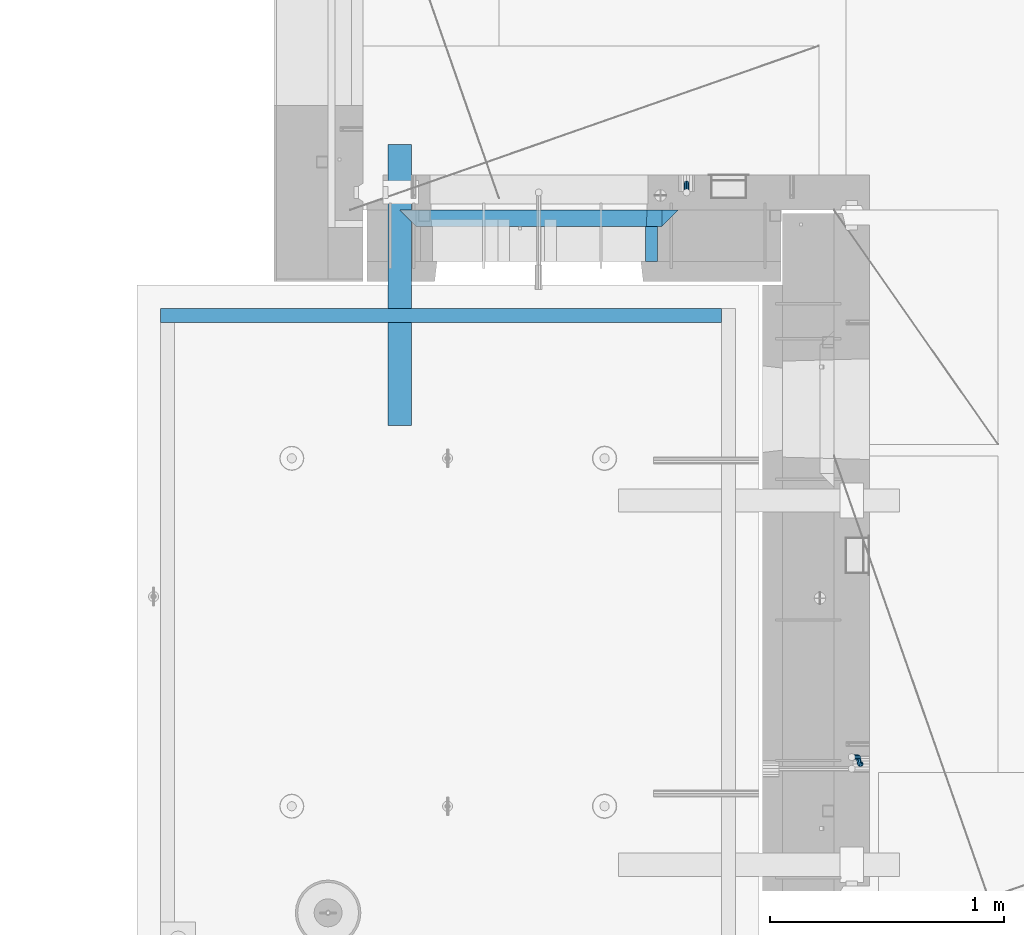
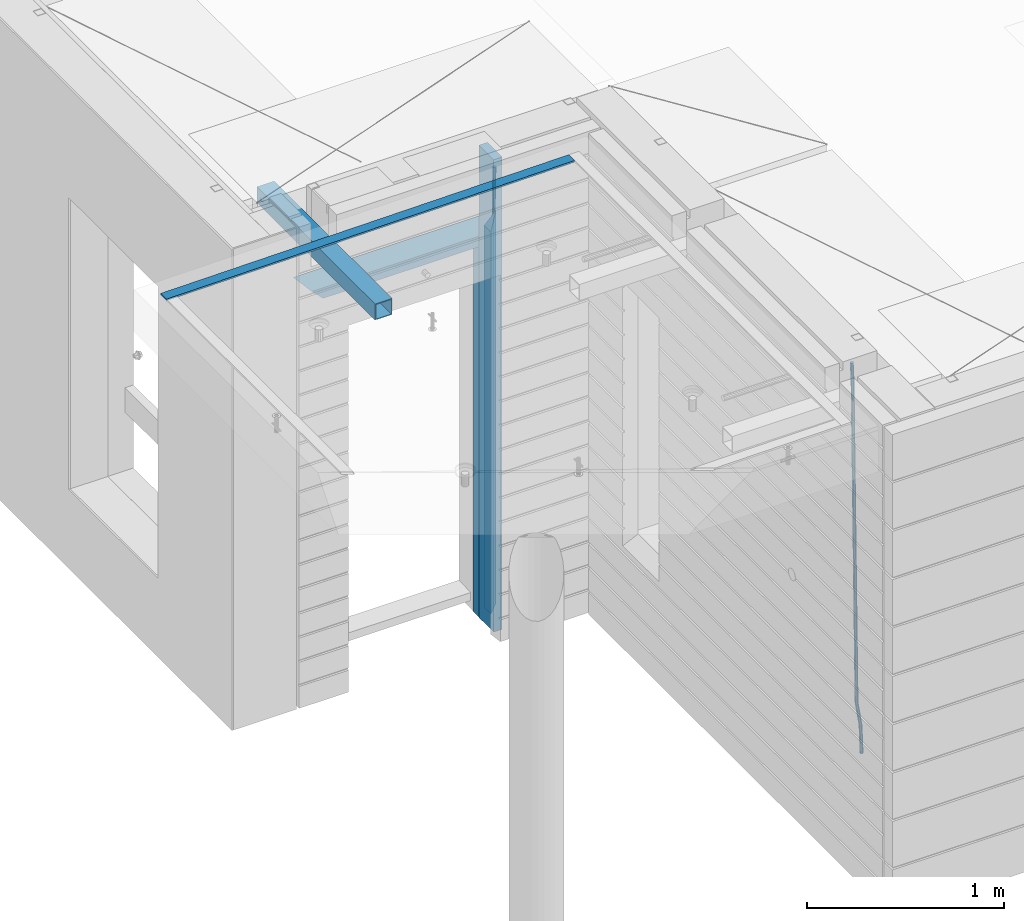
# One storey, part 94 of 349: 9 beams, 4 elements without a shape of their own.
"""IFC2X3 building model written with IfcOpenShell, lengths in millimetres."""

from ifc_helpers import new_model, si_unit, frame, origin_with_axes, place, context, subcontext, project, spatial, faceted_brep, material, type_object, element, aggregate, save


model = new_model("IFC2X3")

# Units and contexts
model_context = context("Model", 3, precision=1e-05, world=origin_with_axes())
body_context = subcontext(model_context, "Body", "Model", "MODEL_VIEW")
ifc_project = project(units=[si_unit("LENGTHUNIT", "METRE", prefix="MILLI"), si_unit("AREAUNIT", "SQUARE_METRE"), si_unit("VOLUMEUNIT", "CUBIC_METRE"), si_unit("MASSUNIT", "GRAM", prefix="KILO"), si_unit("TIMEUNIT", "SECOND"), si_unit("PLANEANGLEUNIT", "RADIAN"), si_unit("SOLIDANGLEUNIT", "STERADIAN"), si_unit("THERMODYNAMICTEMPERATUREUNIT", "DEGREE_CELSIUS"), si_unit("LUMINOUSINTENSITYUNIT", "LUMEN")], contexts=[model_context])

# Site, building, storey
site_placement = place(None, origin_with_axes())
site = spatial("IfcSite", under=ifc_project, at=site_placement, CompositionType="ELEMENT")
building_placement = place(site_placement, origin_with_axes())
building = spatial("IfcBuilding", under=site, at=building_placement, CompositionType="ELEMENT")
storey_placement = place(building_placement, origin_with_axes())
storey = spatial("IfcBuildingStorey", under=building, at=storey_placement, Name="4", CompositionType="ELEMENT", Elevation=0.0)

# Assembly, beams
assembly_1_placement = place(storey_placement, origin_with_axes())
assembly_1 = element("IfcElementAssembly", 1, at=assembly_1_placement, inside=storey, AssemblyPlace="NOTDEFINED", PredefinedType="REINFORCEMENT_UNIT")
ifc_material_1 = material(Name="CONCRETE/C25/30")
beam_type_1 = type_object("IfcBeamType", PredefinedType="NOTDEFINED")
beam_1_placement = place(assembly_1_placement, frame((8155.00084638596, 10914.9999977209, 93160.0), z_axis=(0.0, 0.0, -1.0), x_axis=(1.0, 0.0, 0.0)))
beam_1 = element("IfcBeam", 2, at=beam_1_placement, type_object=beam_type_1, material=ifc_material_1, Name="SK", context=body_context, shape_type="Brep", body=[
    faceted_brep([(70.0000000000164, -35.0, 35.0), (70.0000000000164, 35.0, 35.0), (0.0, -35.0, -35.0), (1189.99771118164, -35.0, -35.0), (1119.99771118163, -35.0, 35.0), (1119.99771118163, 35.0, 35.0)], [[[0, 1, 2]], [[0, 2, 3, 4]], [[1, 0, 4, 5]], [[2, 1, 5, 3]], [[4, 3, 5]]]),
])
beam_2_placement = place(assembly_1_placement, frame((8225.00084638596, 10914.9999988604, 93090.0), z_axis=(0.0, 0.0, -1.0), x_axis=(1.0, 0.0, 0.0)))
beam_2 = element("IfcBeam", 3, at=beam_2_placement, type_object=beam_type_1, material=ifc_material_1, Name="SK", context=body_context, shape_type="Brep", body=[
    faceted_brep([(0.0, -35.0, -35.0), (64.051765297294, -34.9999988604341, 29.0540541156515), (65.9436571275874, 34.9999988604341, 30.9459459459467), (0.0, 35.0, -35.0), (1049.99771118164, -34.9999988604341, -35.0), (985.943657065987, -34.9999988604341, 29.0540541156515), (984.051765235694, 34.9999988604341, 30.9459459459467), (1049.99771118164, 34.9999988604341, -35.0)], [[[0, 1, 2, 3]], [[1, 0, 4, 5]], [[2, 1, 5, 6]], [[3, 2, 6, 7]], [[0, 3, 7, 4]], [[6, 5, 4, 7]]]),
])
beam_3_placement = place(assembly_1_placement, frame((9309.9985575676, 10914.9999977209, 93195.0), z_axis=(-1.0, 3.00000001838171e-08, 0.0), x_axis=(0.0, 0.0, -1.0)))
beam_3 = element("IfcBeam", 4, at=beam_3_placement, type_object=beam_type_1, material=ifc_material_1, Name="SK", context=body_context, shape_type="Brep", body=[
    faceted_brep([(2440.0, -35.0, 35.0), (2440.0, -35.0, -35.0), (2440.0, 35.0, 35.0), (0.0, -35.0, -35.0), (70.0000000000164, 35.0, 35.0), (70.0000000000164, -35.0, 35.0)], [[[0, 1, 2]], [[2, 1, 3, 4]], [[0, 2, 4, 5]], [[1, 0, 5, 3]], [[5, 4, 3]]]),
])
beam_4_placement = place(assembly_1_placement, frame((9239.9985575676, 10914.9999988604, 93125.0), z_axis=(-1.0, 3.00000001838171e-08, 0.0), x_axis=(0.0, 0.0, -1.0)))
beam_4 = element("IfcBeam", 5, at=beam_4_placement, type_object=beam_type_1, material=ifc_material_1, Name="SK", context=body_context, shape_type="Brep", body=[
    faceted_brep([(2370.0, -34.9999988604341, -35.0), (2370.0, 34.9999988604341, -35.0), (2370.0, 34.9999988604341, 30.9459459459467), (2370.0, -34.9999988604341, 29.0540541156515), (0.0, -35.0, -35.0), (0.0, 35.0, -35.0), (65.9459459459467, 34.9999988604341, 30.9459459459467), (64.0540541156515, -34.9999988604341, 29.0540541156533)], [[[0, 1, 2, 3]], [[4, 5, 1, 0]], [[2, 1, 5, 6]], [[3, 2, 6, 7]], [[0, 3, 7, 4]], [[6, 5, 4, 7]]]),
])
ifc_material_2 = material(Name="TIMBER")
beam_type_2 = type_object("IfcBeamType", Name="50X150", PredefinedType="NOTDEFINED")
beam_5_placement = place(assembly_1_placement, frame((9229.9985575676, 10804.9999977209, 93690.0), z_axis=(-1.0, 3.00000001838171e-08, 0.0), x_axis=(0.0, 0.0, -1.0)))
beam_5 = element("IfcBeam", 6, at=beam_5_placement, type_object=beam_type_2, material=ifc_material_2, ObjectType="50X150", context=body_context, shape_type="Brep", body=[
    faceted_brep([(0.0, 75.0, -25.0), (1.81898940354586e-12, 75.0, 25.0), (2930.0, 75.0, 25.0), (2930.0, 75.0, -25.0), (1.81898940354586e-12, -75.0000000000009, 25.0), (2930.0, -75.0, 25.0), (0.0, -75.0, -25.0), (2930.0, -75.0, -25.0)], [[[0, 1, 2, 3]], [[1, 4, 5, 2]], [[4, 6, 7, 5]], [[6, 0, 3, 7]], [[5, 7, 3, 2]], [[6, 4, 1, 0]]]),
])
ifc_material_3 = material()
beam_type_3 = type_object("IfcBeamType", Name="D20", PredefinedType="NOTDEFINED")
beam_6_placement = place(assembly_1_placement, frame((9379.9982799665, 11065.0, 91790.0), z_axis=(0.00020576299992186, -0.999642804629538, -0.0267249099901004), x_axis=(-4.30000201928125e-08, -0.0267249099948059, 0.999642825806181)))
beam_6 = element("IfcBeam", 7, at=beam_6_placement, type_object=beam_type_3, material=ifc_material_3, Name="JM20", ObjectType="D20", context=body_context, shape_type="Brep", body=[
    faceted_brep([(0.0, -10.0, 0.0), (-4.19531716033816e-08, -7.07106781186667, -7.07106781187031), (60.4266690400545, -7.0710677960451, -7.07106780570757), (60.4266690441291, -9.99999998418934, 6.15546014159918e-09), (0.0, 0.0, -10.0), (60.426669036824, 1.58106558956206e-08, -9.99999999384454), (4.196772351861e-08, 7.07106781186303, -7.07106781186667), (60.4266690363438, 7.07106782768096, -7.07106780570757), (0.0, 10.0, 0.0), (60.4266690388904, 10.0000000158179, 6.15182216279209e-09), (4.196772351861e-08, 7.07106781185939, 7.07106781185939), (60.4266690429649, 7.07106782768096, 7.07106781802577), (0.0, 0.0, 10.0), (60.4266690461809, 1.58179318532348e-08, 10.0000000061555), (-4.19531716033816e-08, -7.07106781187031, 7.07106781185939), (60.4266690466611, -7.07106779605238, 7.07106781802213), (61.0378400410118, -7.07106779588503, -7.07106780564936), (60.991799419251, -9.99999998403655, 6.21366780251265e-09), (61.0569027789461, 1.5985278878361e-08, -9.99999999378269), (61.0378209396877, 7.07106782784831, -7.07106780564936), (60.9917724058905, 10.0000000159635, 6.21366780251265e-09), (60.9457317841297, 7.07106782781193, 7.0710678180767), (60.9266690461809, 1.59488990902901e-08, 10.0000000062028), (60.9457508854539, -7.07106779591413, 7.0710678180767), (61.6489592143771, -7.07106614513759, -7.06310863441468), (61.5568818710308, -9.9999984576425, 0.00735959856683621), (61.6870830769039, 1.71821739058942e-06, -9.99179257185824), (61.6489210170112, 7.07106947854481, -7.06310888312146), (61.556827851804, 10.0000015422847, 0.00735924683976918), (61.4647505084577, 7.07106922979438, 7.07782747982128), (61.4266266459163, 1.36643211590126e-06, 10.0065114172685), (61.464788705809, -7.07106639389531, 7.07782772852806), (176.543135720174, -7.07075579406956, -5.56673531796696), (176.451058376813, -9.99968810657447, 1.50373291501455), (176.581259582701, 0.000312069292704109, -8.49541925541052), (176.543097522794, 7.07137982961285, -5.56673556667374), (176.451004357587, 10.00031189336, 1.50373256329476), (176.35892701424, 7.07137958085514, 8.57420079627263), (176.320803151699, 0.000311717507429421, 11.5028847337162), (176.358965211621, -7.07075604281999, 8.57420104497578), (177.098753836006, -7.07075429323595, -5.55949898843028), (176.98362511232, -9.99968666800123, 1.510669025065), (177.146421932586, 0.000313595905026887, -8.48805862247536), (177.098706077581, 7.07138133041735, -5.55949936166144), (176.983557571715, 10.0003133318824, 1.51066849724157), (176.868428848029, 7.07138095712435, 8.58083651073321), (176.820760751449, 0.000313067976094317, 11.5093961447819), (176.868476606425, -7.07075466652896, 8.58083688396073), (177.654312950661, -7.07075204110879, -5.54863964998367), (177.516135294456, -9.99968450931192, 1.52107783331303), (177.711524267797, 0.000315886711177882, -8.47701274570863), (177.654255632195, 7.07138358250813, -5.54864021007961), (177.516054233929, 10.0003154905207, 1.5210770412159), (177.377876577739, 7.0713830223176, 8.59079452451624), (177.320665260588, 0.000315094497636892, 11.5191676202448), (177.377933896176, -7.07075260129932, 8.59079508461218), (299.475681513461, -7.07025820503441, -3.16743615469204), (299.337503857227, -9.99919067323572, 3.9022813287429), (299.532892830684, 0.000809722789199441, -6.09580925047521), (299.475624195184, 7.0718774185807, -3.16743671478434), (299.337422796933, 10.0008093266006, 3.9022805366476), (299.199245140699, 7.07187685839926, 10.9719980200825), (299.142033823475, 0.000808930573839461, 13.9003711158675), (299.199302458976, -7.07025876521584, 10.9719985801767), (300.014932281207, -7.07025601902387, -3.15689559088241), (299.971788958996, -9.99918809853989, 3.91467979818117), (300.032797339853, 0.000811749296190101, -6.08603777550707), (300.014914236686, 7.07187960474585, -3.15689538330298), (299.971753863239, 10.0008119014747, 3.91467990454839), (299.928610539675, 7.07187981509378, 10.9862546943223), (299.910745481058, 0.000812046770079178, 13.9153968789487), (299.92862858421, -7.07025580868321, 10.9862544867447), (300.554271526576, -7.07025682891253, -3.16085443148222), (300.606168552113, -9.999189054608, 3.91002291708173), (300.532783870876, 0.00081099850103783, -6.08970776057868), (300.554292762245, 7.0718787948008, -3.16085451222716), (300.606198583846, 10.0008109453684, 3.9100228028874), (300.658095609382, 7.07187871967653, 10.9809001514495), (300.679583265097, 0.000810892259323737, 13.9097534805496), (300.658074373729, -7.07025690404043, 10.9809002321963), (1493.73308072364, -7.07204854080373, -11.9189871896033), (1493.78497774916, -10.0009807664974, -4.84810984104297), (1493.71159306791, -0.000980713386525167, -14.8478405187034), (1493.7331019593, 7.07008708290959, -11.9189872703519), (1493.7850077809, 9.99901923348079, -4.84810995523549), (1493.83690480642, 7.07008700778533, 2.22276739332847), (1493.85839246215, -0.000980819630058249, 5.15162072242492), (1493.83688357078, -7.07204861592982, 2.22276747407341), (1494.37906755973, -7.07204951083804, -11.9237288414206), (1494.33887067712, -10.0009815982412, -4.85217550811467), (1494.43391396098, -0.000981798046268523, -14.853142475311), (1494.47128160285, 7.07008597443928, -11.9244056328516), (1494.46928102754, 9.99901820595551, -4.85313263573335), (1494.42908414494, 7.07008611855053, 2.2184206975744), (1494.37423774367, -0.000981594239419792, 5.14783433146476), (1494.3368701018, -7.07204936672315, 2.21909748900362), (1495.02495968822, -7.08047207584605, -11.9151326558385), (1494.89268239928, -10.0082034159841, -4.84480482169238), (1495.15612895518, -0.0103996287834889, -14.8435305078528), (1495.20935302251, 7.06046137268277, -11.9145826320491), (1495.15345395346, 9.99009645154365, -4.84402697058613), (1495.02117666451, 7.06236511140742, 2.22630086356003), (1494.89000739757, -0.0077073356587789, 5.15469871557252), (1494.83678333023, -7.07856833711958, 2.22575083976881), (1516.81232084993, -7.36458370639957, -11.6251644217427), (1516.68004356099, -10.292315046534, -4.55483658759658), (1516.94349011689, -0.294511259335195, -14.5535622737552), (1516.99671418422, 6.77634974212924, -11.6246143979515), (1516.94081511517, 9.70598482099194, -4.55405873649033), (1516.80853782622, 6.77825348085389, 2.51626909765582), (1516.67736855928, -0.291818966210485, 5.44466694967014), (1516.62414449194, -7.36267996767492, 2.51571907386642), (1517.44776642873, -7.37287004627251, -11.6167072694061), (1517.34013338278, -10.3009227523598, -4.54605144475318), (1517.52181307798, -0.302052708628253, -14.5458653669793), (1517.51889780765, 6.76954036124152, -11.6176646502499), (1517.44072834359, 9.69946585059188, -4.54740538572696), (1517.33309529764, 6.77141314450637, 2.52325043892597), (1517.2590486484, -0.299404193137889, 5.45240853650103), (1517.26196391872, -7.37099726300949, 2.52420781977162), (1518.08326583009, -7.37099400012448, -11.6084451566603), (1518.00027896308, -10.2989541927, -4.53746177004541), (1518.10018527637, -0.300354896351564, -14.5383632714329), (1518.04112611974, 6.77107862627236, -11.610909819372), (1517.9406844132, 9.70095671561285, -4.54094732948215), (1517.85769754619, 6.77299652303554, 2.53003605713457), (1517.84077809991, -0.297642580735555, 5.45995417190716), (1517.89983725653, -7.36907610336129, 2.53250071984621), (1618.10405127065, -7.07273188347062, -10.3110710264427), (1618.02106440364, -10.0006920760461, -3.24008763982602), (1618.12097071693, -0.00209277969770483, -13.2409891412153), (1618.06191156032, 7.06934074292622, -10.3135356891544), (1617.96146985376, 9.99921883226671, -3.24357319926276), (1617.87848298675, 7.07125863968758, 3.82741018735396), (1617.86156354047, 0.000619535918303882, 6.75732830212473), (1617.92062269709, -7.07081398670744, 3.82987485006379)], [[[0, 1, 2, 3]], [[1, 4, 5, 2]], [[4, 6, 7, 5]], [[6, 8, 9, 7]], [[8, 10, 11, 9]], [[10, 12, 13, 11]], [[12, 14, 15, 13]], [[14, 0, 3, 15]], [[14, 12, 10, 8, 6, 4, 1, 0]], [[3, 2, 16, 17]], [[2, 5, 18, 16]], [[5, 7, 19, 18]], [[7, 9, 20, 19]], [[9, 11, 21, 20]], [[11, 13, 22, 21]], [[13, 15, 23, 22]], [[15, 3, 17, 23]], [[17, 16, 24, 25]], [[16, 18, 26, 24]], [[18, 19, 27, 26]], [[19, 20, 28, 27]], [[20, 21, 29, 28]], [[21, 22, 30, 29]], [[22, 23, 31, 30]], [[23, 17, 25, 31]], [[25, 24, 32, 33]], [[24, 26, 34, 32]], [[26, 27, 35, 34]], [[27, 28, 36, 35]], [[28, 29, 37, 36]], [[29, 30, 38, 37]], [[30, 31, 39, 38]], [[31, 25, 33, 39]], [[33, 32, 40, 41]], [[32, 34, 42, 40]], [[34, 35, 43, 42]], [[35, 36, 44, 43]], [[36, 37, 45, 44]], [[37, 38, 46, 45]], [[38, 39, 47, 46]], [[39, 33, 41, 47]], [[41, 40, 48, 49]], [[40, 42, 50, 48]], [[42, 43, 51, 50]], [[43, 44, 52, 51]], [[44, 45, 53, 52]], [[45, 46, 54, 53]], [[46, 47, 55, 54]], [[47, 41, 49, 55]], [[49, 48, 56, 57]], [[48, 50, 58, 56]], [[50, 51, 59, 58]], [[51, 52, 60, 59]], [[52, 53, 61, 60]], [[53, 54, 62, 61]], [[54, 55, 63, 62]], [[55, 49, 57, 63]], [[57, 56, 64, 65]], [[56, 58, 66, 64]], [[58, 59, 67, 66]], [[59, 60, 68, 67]], [[60, 61, 69, 68]], [[61, 62, 70, 69]], [[62, 63, 71, 70]], [[63, 57, 65, 71]], [[65, 64, 72, 73]], [[64, 66, 74, 72]], [[66, 67, 75, 74]], [[67, 68, 76, 75]], [[68, 69, 77, 76]], [[69, 70, 78, 77]], [[70, 71, 79, 78]], [[71, 65, 73, 79]], [[73, 72, 80, 81]], [[72, 74, 82, 80]], [[74, 75, 83, 82]], [[75, 76, 84, 83]], [[76, 77, 85, 84]], [[77, 78, 86, 85]], [[78, 79, 87, 86]], [[79, 73, 81, 87]], [[81, 80, 88, 89]], [[80, 82, 90, 88]], [[82, 83, 91, 90]], [[83, 84, 92, 91]], [[84, 85, 93, 92]], [[85, 86, 94, 93]], [[86, 87, 95, 94]], [[87, 81, 89, 95]], [[89, 88, 96, 97]], [[88, 90, 98, 96]], [[90, 91, 99, 98]], [[91, 92, 100, 99]], [[92, 93, 101, 100]], [[93, 94, 102, 101]], [[94, 95, 103, 102]], [[95, 89, 97, 103]], [[97, 96, 104, 105]], [[96, 98, 106, 104]], [[98, 99, 107, 106]], [[99, 100, 108, 107]], [[100, 101, 109, 108]], [[101, 102, 110, 109]], [[102, 103, 111, 110]], [[103, 97, 105, 111]], [[105, 104, 112, 113]], [[104, 106, 114, 112]], [[106, 107, 115, 114]], [[107, 108, 116, 115]], [[108, 109, 117, 116]], [[109, 110, 118, 117]], [[110, 111, 119, 118]], [[111, 105, 113, 119]], [[113, 112, 120, 121]], [[112, 114, 122, 120]], [[114, 115, 123, 122]], [[115, 116, 124, 123]], [[116, 117, 125, 124]], [[117, 118, 126, 125]], [[118, 119, 127, 126]], [[119, 113, 121, 127]], [[121, 120, 128, 129]], [[120, 122, 130, 128]], [[122, 123, 131, 130]], [[123, 124, 132, 131]], [[124, 125, 133, 132]], [[125, 126, 134, 133]], [[126, 127, 135, 134]], [[127, 121, 129, 135]], [[130, 131, 132, 133, 134, 135, 129, 128]]]),
])
aggregate(assembly_1, [beam_6, beam_1, beam_2, beam_3, beam_4, beam_5])

# Assembly, beam
assembly_2_placement = place(storey_placement, origin_with_axes())
assembly_2 = element("IfcElementAssembly", 8, at=assembly_2_placement, inside=storey, AssemblyPlace="NOTDEFINED", PredefinedType="REINFORCEMENT_UNIT")
beam_7_placement = place(assembly_2_placement, frame((10125.0000000031, 8585.0017200335, 90989.9999999969), z_axis=(-0.999642804636942, -0.000205726999925762, -0.0267249099902983), x_axis=(-0.0267249099948371, 4.30000201934385e-08, 0.999642825806181)))
beam_7 = element("IfcBeam", 9, at=beam_7_placement, type_object=beam_type_3, material=ifc_material_3, Name="JM20", ObjectType="D20", context=body_context, shape_type="Brep", body=[
    faceted_brep([(0.0, -10.0, 0.0), (-4.19531716033816e-08, -7.07106781186667, -7.07106781187031), (60.4266690400545, -7.0710677960451, -7.07106780570757), (60.4266690441291, -9.99999998418934, 6.15546014159918e-09), (0.0, 0.0, -10.0), (60.426669036824, 1.58106558956206e-08, -9.99999999384454), (4.196772351861e-08, 7.07106781186303, -7.07106781186667), (60.4266690363438, 7.07106782768096, -7.07106780570757), (0.0, 10.0, 0.0), (60.4266690388904, 10.0000000158179, 6.15182216279209e-09), (4.196772351861e-08, 7.07106781185939, 7.07106781185939), (60.4266690429649, 7.07106782768096, 7.07106781802577), (0.0, 0.0, 10.0), (60.4266690461809, 1.58179318532348e-08, 10.0000000061555), (-4.19531716033816e-08, -7.07106781187031, 7.07106781185939), (60.4266690466611, -7.07106779605238, 7.07106781802213), (61.0378400410118, -7.07106779588503, -7.07106780564936), (60.991799419251, -9.99999998403655, 6.21366780251265e-09), (61.0569027789461, 1.5985278878361e-08, -9.99999999378269), (61.0378209396877, 7.07106782784831, -7.07106780564936), (60.9917724058905, 10.0000000159635, 6.21366780251265e-09), (60.9457317841297, 7.07106782781193, 7.0710678180767), (60.9266690461809, 1.59488990902901e-08, 10.0000000062028), (60.9457508854539, -7.07106779591413, 7.0710678180767), (61.6489592143771, -7.07106614513759, -7.06310863441468), (61.5568818710308, -9.9999984576425, 0.00735959856683621), (61.6870830769039, 1.71821739058942e-06, -9.99179257185824), (61.6489210170112, 7.07106947854481, -7.06310888312146), (61.556827851804, 10.0000015422847, 0.00735924683976918), (61.4647505084577, 7.07106922979438, 7.07782747982128), (61.4266266459163, 1.36643211590126e-06, 10.0065114172685), (61.464788705809, -7.07106639389531, 7.07782772852806), (175.37403592006, -7.07075895339585, -5.5819617630732), (175.281958576699, -9.99969126589349, 1.48850647000108), (175.412159782674, 0.000308909964587656, -8.51064570055678), (175.373997722811, 7.07137667028292, -5.58196201177816), (175.281904557633, 10.0003087340338, 1.48850611827766), (175.189827214257, 7.07137642153248, 8.55897435135012), (175.151703351657, 0.000308558175674989, 11.4876582888337), (175.189865411507, -7.07075920214811, 8.55897460005508), (177.947973008238, -7.07075200072177, -5.54843899804655), (178.185320525896, -9.99968342338434, 1.52631963989006), (177.145703789589, 0.000313592583552236, -8.48806815245916), (176.248471297557, 7.07137903239709, -5.57057293303842), (175.781862157353, 10.0003100845097, 1.49501752883771), (176.019209675011, 7.07137866184712, 8.56977616677796), (176.82147889366, 0.000313068545438, 11.5094053211888), (177.718711385693, -7.07075237127174, 8.59191010176619), (180.448353003565, -6.46083449902471, -5.49969035980757), (181.005711191348, -9.31170574331372, 1.58130736355633), (178.829707169425, 0.411092408678087, -8.45523599426269), (177.097954465877, 7.27859339690076, -5.55401099135815), (176.267532139987, 10.118779526354, 1.50448638970374), (176.824890327771, 7.26790828206686, 8.58548411306947), (178.443536161911, 0.395981374362236, 11.5410297475228), (180.175288865445, -6.47151961386044, 8.63980474461823), (300.130679507536, 22.7332662835124, -3.16630485466521), (300.688037695305, 19.8823950392234, 3.91469286870233), (298.512033673396, 29.6051931912152, -6.12185048911851), (296.780280969833, 36.4726941794397, -3.22062548621216), (295.949858643944, 39.312880308893, 3.83787189484792), (296.507216831713, 36.462009064604, 10.9188696182155), (298.125862665867, 29.5900821569012, 13.8744152526688), (299.85761536943, 22.7225811686749, 10.9731902497624), (300.838254221671, 22.9058649296021, -3.15250963000472), (301.173707677939, 20.0008644810696, 3.92416172956655), (299.995227641819, 29.9669885828916, -6.09293340998011), (299.138461475406, 37.0479249704349, -3.1746492391685), (298.769837722954, 40.0007575907111, 3.89285159402425), (299.105291179221, 37.0957571421768, 10.9695229535973), (299.948317759059, 30.0346334888854, 13.9099467335673), (300.805083925487, 22.9536971013422, 10.9916625627593), (301.566623170889, 22.9058626555343, -3.16352102199562), (301.673650550176, 20.0008629201784, 3.91660365485041), (301.522009776192, 29.9669838160717, -6.1160151140848), (301.565944287635, 37.0479173915064, -3.21134762509791), (301.672690464271, 40.0007485276092, 3.84896662410392), (301.779717843558, 37.0957487922533, 10.9290913009499), (301.82433123824, 30.0346276317159, 13.881585393041), (301.780396726797, 22.953694056283, 10.9769179040522), (2293.36508471855, 22.8996439899911, -33.2752846422391), (2293.47211209782, 19.9946442546316, -26.195159965393), (2293.32047132387, 29.9607651505266, -36.2277787343282), (2293.36440583531, 37.0416987259578, -33.3231112453414), (2293.47115201195, 39.9945298620642, -26.2627969961413), (2293.5781793912, 37.0895301267083, -19.1826723192917), (2293.6227927859, 30.0284089661727, -16.2301782272025), (2293.57885827446, 22.947475390738, -19.134845716193), (2294.06569143596, 22.8996418025999, -33.2858763282329), (2294.05315457586, 19.9946424405407, -26.2039440939534), (2294.10906780435, 29.9607626884226, -36.2397006387127), (2294.15787439278, 37.0416962486433, -33.3351068051852), (2294.18352096362, 39.9945276379531, -26.2735665021428), (2294.17098410353, 37.089528275892, -19.1916342678614), (2294.12760773512, 30.0284073900693, -16.2378099573798), (2294.07880114671, 22.9474738298504, -19.1424037909092), (2294.76625661059, 22.8905062380709, -33.2765524984534), (2294.63416260075, 19.9870659344633, -26.1962114516227), (2294.89761752472, 29.9504797809677, -36.2292058216281), (2294.95129590121, 37.0313498117212, -33.3245471494174), (2294.8958476751, 39.9852386997136, -26.2640861379368), (2294.76375366526, 37.0817983961042, -19.1837450911044), (2294.63239275114, 30.0218248532074, -16.2310917679315), (2294.57871437464, 22.9409548224558, -19.135750440144), (2316.52593703129, 22.6067539594387, -32.9869526673174), (2316.39384302145, 19.7033136558293, -25.9066116204867), (2316.65729794541, 29.6667275023337, -35.9396059904902), (2316.71097632191, 36.7475975330854, -33.0349473182796), (2316.6555280958, 39.7014864210796, -25.974486306799), (2316.52343408595, 36.798046117472, -18.8941452599665), (2316.39207317181, 29.7380725745734, -15.9414919367919), (2316.33839479534, 22.6572025438199, -18.8461506090043), (2317.16158675382, 22.5984649104412, -32.9784927980199), (2317.05394423746, 19.6947057525631, -25.8978263259869), (2317.23590155228, 29.6591823505332, -35.931905348587), (2317.23335603178, 36.740785556527, -33.0279949608521), (2317.15544132373, 39.6949674136868, -25.967832956032), (2317.04779880737, 36.7912082558087, -18.887166483999), (2316.97348400892, 29.730490815713, -15.9337539334319), (2316.97602952941, 22.648887609721, -18.8376643211668), (2317.79729034709, 22.6003447382427, -32.9702310967514), (2317.71410127044, 19.6966744277033, -25.8892409069249), (2317.81455440674, 29.660885407864, -35.9243995360212), (2317.75578039732, 36.7423274699941, -33.021234418542), (2317.65539733646, 39.6964582057935, -25.9613704963267), (2317.57220825978, 36.7927878952578, -18.8803803065002), (2317.55494420015, 29.7322472256365, -15.9262118672305), (2317.6137182096, 22.6508051635028, -18.8293769847114), (2417.81807008978, 22.8986075784269, -31.6728570405921), (2417.73488101311, 19.9949372678893, -24.5918668507657), (2417.83533414939, 29.9591482480482, -34.6270254798619), (2417.77656013996, 37.0405903101819, -31.7238603623846), (2417.67617707912, 39.9947210459814, -24.6639964401675), (2417.59298800245, 37.0910507354438, -17.5830062503428), (2417.57572394283, 30.0305100658206, -14.628837811073), (2417.63449795225, 22.9490680036906, -17.5320029285504)], [[[0, 1, 2, 3]], [[1, 4, 5, 2]], [[4, 6, 7, 5]], [[6, 8, 9, 7]], [[8, 10, 11, 9]], [[10, 12, 13, 11]], [[12, 14, 15, 13]], [[14, 0, 3, 15]], [[14, 12, 10, 8, 6, 4, 1, 0]], [[3, 2, 16, 17]], [[2, 5, 18, 16]], [[5, 7, 19, 18]], [[7, 9, 20, 19]], [[9, 11, 21, 20]], [[11, 13, 22, 21]], [[13, 15, 23, 22]], [[15, 3, 17, 23]], [[17, 16, 24, 25]], [[16, 18, 26, 24]], [[18, 19, 27, 26]], [[19, 20, 28, 27]], [[20, 21, 29, 28]], [[21, 22, 30, 29]], [[22, 23, 31, 30]], [[23, 17, 25, 31]], [[25, 24, 32, 33]], [[24, 26, 34, 32]], [[26, 27, 35, 34]], [[27, 28, 36, 35]], [[28, 29, 37, 36]], [[29, 30, 38, 37]], [[30, 31, 39, 38]], [[31, 25, 33, 39]], [[33, 32, 40, 41]], [[32, 34, 42, 40]], [[34, 35, 43, 42]], [[35, 36, 44, 43]], [[36, 37, 45, 44]], [[37, 38, 46, 45]], [[38, 39, 47, 46]], [[39, 33, 41, 47]], [[41, 40, 48, 49]], [[40, 42, 50, 48]], [[42, 43, 51, 50]], [[43, 44, 52, 51]], [[44, 45, 53, 52]], [[45, 46, 54, 53]], [[46, 47, 55, 54]], [[47, 41, 49, 55]], [[49, 48, 56, 57]], [[48, 50, 58, 56]], [[50, 51, 59, 58]], [[51, 52, 60, 59]], [[52, 53, 61, 60]], [[53, 54, 62, 61]], [[54, 55, 63, 62]], [[55, 49, 57, 63]], [[57, 56, 64, 65]], [[56, 58, 66, 64]], [[58, 59, 67, 66]], [[59, 60, 68, 67]], [[60, 61, 69, 68]], [[61, 62, 70, 69]], [[62, 63, 71, 70]], [[63, 57, 65, 71]], [[65, 64, 72, 73]], [[64, 66, 74, 72]], [[66, 67, 75, 74]], [[67, 68, 76, 75]], [[68, 69, 77, 76]], [[69, 70, 78, 77]], [[70, 71, 79, 78]], [[71, 65, 73, 79]], [[73, 72, 80, 81]], [[72, 74, 82, 80]], [[74, 75, 83, 82]], [[75, 76, 84, 83]], [[76, 77, 85, 84]], [[77, 78, 86, 85]], [[78, 79, 87, 86]], [[79, 73, 81, 87]], [[81, 80, 88, 89]], [[80, 82, 90, 88]], [[82, 83, 91, 90]], [[83, 84, 92, 91]], [[84, 85, 93, 92]], [[85, 86, 94, 93]], [[86, 87, 95, 94]], [[87, 81, 89, 95]], [[89, 88, 96, 97]], [[88, 90, 98, 96]], [[90, 91, 99, 98]], [[91, 92, 100, 99]], [[92, 93, 101, 100]], [[93, 94, 102, 101]], [[94, 95, 103, 102]], [[95, 89, 97, 103]], [[97, 96, 104, 105]], [[96, 98, 106, 104]], [[98, 99, 107, 106]], [[99, 100, 108, 107]], [[100, 101, 109, 108]], [[101, 102, 110, 109]], [[102, 103, 111, 110]], [[103, 97, 105, 111]], [[105, 104, 112, 113]], [[104, 106, 114, 112]], [[106, 107, 115, 114]], [[107, 108, 116, 115]], [[108, 109, 117, 116]], [[109, 110, 118, 117]], [[110, 111, 119, 118]], [[111, 105, 113, 119]], [[113, 112, 120, 121]], [[112, 114, 122, 120]], [[114, 115, 123, 122]], [[115, 116, 124, 123]], [[116, 117, 125, 124]], [[117, 118, 126, 125]], [[118, 119, 127, 126]], [[119, 113, 121, 127]], [[121, 120, 128, 129]], [[120, 122, 130, 128]], [[122, 123, 131, 130]], [[123, 124, 132, 131]], [[124, 125, 133, 132]], [[125, 126, 134, 133]], [[126, 127, 135, 134]], [[127, 121, 129, 135]], [[130, 131, 132, 133, 134, 135, 129, 128]]]),
])
aggregate(assembly_2, [beam_7])

# Assemblies, beams
assembly_3_placement = place(storey_placement, origin_with_axes())
assembly_3 = element("IfcElementAssembly", 10, at=assembly_3_placement, inside=storey, AssemblyPlace="NOTDEFINED", PredefinedType="REINFORCEMENT_UNIT")
assembly_4_placement = place(assembly_3_placement, origin_with_axes())
assembly_4 = element("IfcElementAssembly", 11, at=assembly_4_placement, AssemblyPlace="NOTDEFINED", PredefinedType="NOTDEFINED")
ifc_material_4 = material(Name="Undefined/350")
beam_type_4 = type_object("IfcBeamType", Name="100X100X5", PredefinedType="NOTDEFINED")
beam_8_placement = place(assembly_4_placement, frame((8154.95985679893, 10029.9865573969, 93555.0), z_axis=(0.0, 0.0, 1.0), x_axis=(2.22429999942101e-05, 0.999999999752625, 0.0)))
beam_8 = element("IfcBeam", 12, at=beam_8_placement, type_object=beam_type_4, material=ifc_material_4, ObjectType="100X100X5", context=body_context, shape_type="Brep", body=[
    faceted_brep([(1160.82642950046, -49.9743978761207, -6.25), (1160.82642783901, -44.9999999999991, -6.25), (1156.25111029171, -44.9999999999991, -10.8253175473074), (1156.25111195316, -49.9743994042774, -10.8253175473074), (1150.00111029171, -44.9999999999991, -12.5), (1150.00111195316, -49.9744014917787, -12.5), (1143.75111029171, -44.9999999999991, -10.8253175473074), (1143.75111195316, -49.9744035792783, -10.8253175473074), (1139.1757927444, -44.9999999999991, -6.25), (1139.17579440585, -49.9744051074349, -6.25), (1137.50111029171, -44.9999999999991, 0.0), (1137.50111195316, -49.9744056667778, 0.0), (1139.1757927444, -44.9999999999991, 6.25), (1139.17579440585, -49.9744051074349, 6.25), (1143.75111029171, -44.9999999999991, 10.8253175473074), (1143.75111195316, -49.9744035792783, 10.8253175473074), (1150.00111029171, -44.9999999999991, 12.5), (1150.00111195316, -49.9744014917787, 12.5), (1156.25111029171, -44.9999999999991, 10.8253175473074), (1156.25111195316, -49.9743994042774, 10.8253175473074), (1160.82642783901, -44.9999999999991, 6.25), (1160.82642950046, -49.9743978761207, 6.25), (1162.50111029171, -44.9999999999991, 0.0), (1162.50111195316, -49.9743973167779, 0.0), (1160.82639777901, 44.9999999999982, -6.25), (1160.82639610046, 50.0256021227788, -6.25), (1156.25107855315, 50.0256005946221, -10.8253175473074), (1156.2510802317, 44.9999999999982, -10.8253175473074), (1150.00107855316, 50.0255985071226, -12.5), (1150.00108023171, 44.9999999999982, -12.5), (1143.75107855316, 50.0255964196231, -10.8253175473074), (1143.75108023171, 44.9999999999982, -10.8253175473074), (1139.17576100585, 50.0255948914664, -6.25), (1139.1757626844, 44.9999999999982, -6.25), (1137.50107855316, 50.0255943321226, 0.0), (1137.5010802317, 44.9999999999982, 0.0), (1139.17576100585, 50.0255948914664, 6.25), (1139.1757626844, 44.9999999999982, 6.25), (1143.75107855316, 50.0255964196231, 10.8253175473074), (1143.75108023171, 44.9999999999982, 10.8253175473074), (1150.00107855316, 50.0255985071226, 12.5), (1150.00108023171, 44.9999999999982, 12.5), (1156.25107855315, 50.0256005946221, 10.8253175473074), (1156.2510802317, 44.9999999999982, 10.8253175473074), (1160.82639610046, 50.0256021227788, 6.25), (1160.82639777901, 44.9999999999982, 6.25), (1162.50107855316, 50.0256026821226, 0.0), (1162.50108023171, 44.9999999999982, 0.0), (1.81898940354586e-12, -50.0000000000009, -50.0), (1.81898940354586e-12, 49.9999999999991, -50.0), (1200.00449189278, 49.9999999999982, -50.0), (1200.00449189278, -50.0000000000009, -50.0), (1.81898940354586e-12, -50.0000000000009, 50.0), (1200.00449189278, -50.0000000000009, 50.0), (1.81898940354586e-12, 49.9999999999991, 50.0), (1200.00449189278, 49.9999999999982, 50.0), (0.0, 44.9999999999991, 45.0), (1.81898940354586e-12, -45.0000000000009, 45.0), (1.81898940354586e-12, -45.0000000000009, -45.0), (0.0, 44.9999999999991, -45.0), (1200.00449189278, 44.9999999999982, -45.0), (1200.00449189278, 44.9999999999982, 45.0), (1200.00449189278, -45.0000000000009, 45.0), (1200.00449189278, -45.0000000000009, -45.0)], [[[0, 1, 2, 3]], [[3, 2, 4, 5]], [[5, 4, 6, 7]], [[7, 6, 8, 9]], [[9, 8, 10, 11]], [[11, 10, 12, 13]], [[13, 12, 14, 15]], [[15, 14, 16, 17]], [[17, 16, 18, 19]], [[19, 18, 20, 21]], [[21, 20, 22, 23]], [[23, 22, 1, 0]], [[24, 25, 26, 27]], [[27, 26, 28, 29]], [[29, 28, 30, 31]], [[31, 30, 32, 33]], [[33, 32, 34, 35]], [[35, 34, 36, 37]], [[37, 36, 38, 39]], [[39, 38, 40, 41]], [[41, 40, 42, 43]], [[43, 42, 44, 45]], [[45, 44, 46, 47]], [[47, 46, 25, 24]], [[48, 49, 50, 51]], [[52, 48, 51, 53], [3, 5, 7, 9, 11, 13, 15, 17, 19, 21, 23, 0]], [[54, 52, 53, 55]], [[48, 52, 54, 49], [56, 57, 58, 59]], [[56, 59, 60, 61], [27, 29, 31, 33, 35, 37, 39, 41, 43, 45, 47, 24]], [[57, 56, 61, 62]], [[58, 57, 62, 63], [18, 16, 14, 12, 10, 8, 6, 4, 2, 1, 22, 20]], [[59, 58, 63, 60]], [[53, 51, 50, 55], [62, 61, 60, 63]], [[49, 54, 55, 50], [42, 40, 38, 36, 34, 32, 30, 28, 26, 25, 46, 44]]]),
])
aggregate(assembly_4, [beam_8])
ifc_material_5 = material(Name="CONCRETE/Concrete_Undefined")
beam_type_5 = type_object("IfcBeamType", PredefinedType="NOTDEFINED")
beam_9_placement = place(assembly_3_placement, frame((9529.73225763201, 10500.0586098955, 93724.6636624749), z_axis=(-0.00918619300035676, -2.22000000585005e-07, 0.99995780603889), x_axis=(-0.999957805748064, -2.41189999941813e-05, -0.00918619299768504)))
beam_9 = element("IfcBeam", 13, at=beam_9_placement, type_object=beam_type_5, material=ifc_material_5, context=body_context, shape_type="Brep", body=[
    faceted_brep([(2.5465851649642e-11, 29.9999999999982, -4.99999999998545), (-2.91038304567337e-11, 29.9999999999982, 5.0), (2394.89682739776, 29.9999999999964, 5.0), (2394.89682739781, 30.0, -4.99999999998545), (-2.5465851649642e-11, -30.0000000000018, 5.0), (2394.89682739776, -30.0000000000036, 5.0), (2.72848410531878e-11, -30.0000000000018, -4.99999999998545), (2394.89682739781, -30.0, -4.99999999998545)], [[[0, 1, 2, 3]], [[1, 4, 5, 2]], [[4, 6, 7, 5]], [[6, 0, 3, 7]], [[5, 7, 3, 2]], [[6, 4, 1, 0]]]),
])
aggregate(assembly_3, [beam_9, assembly_4])

save(model, "model.ifc")
